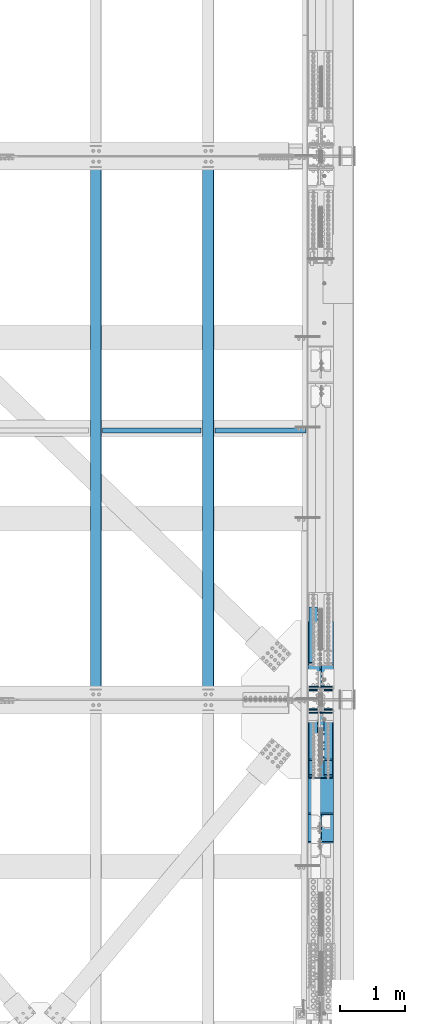
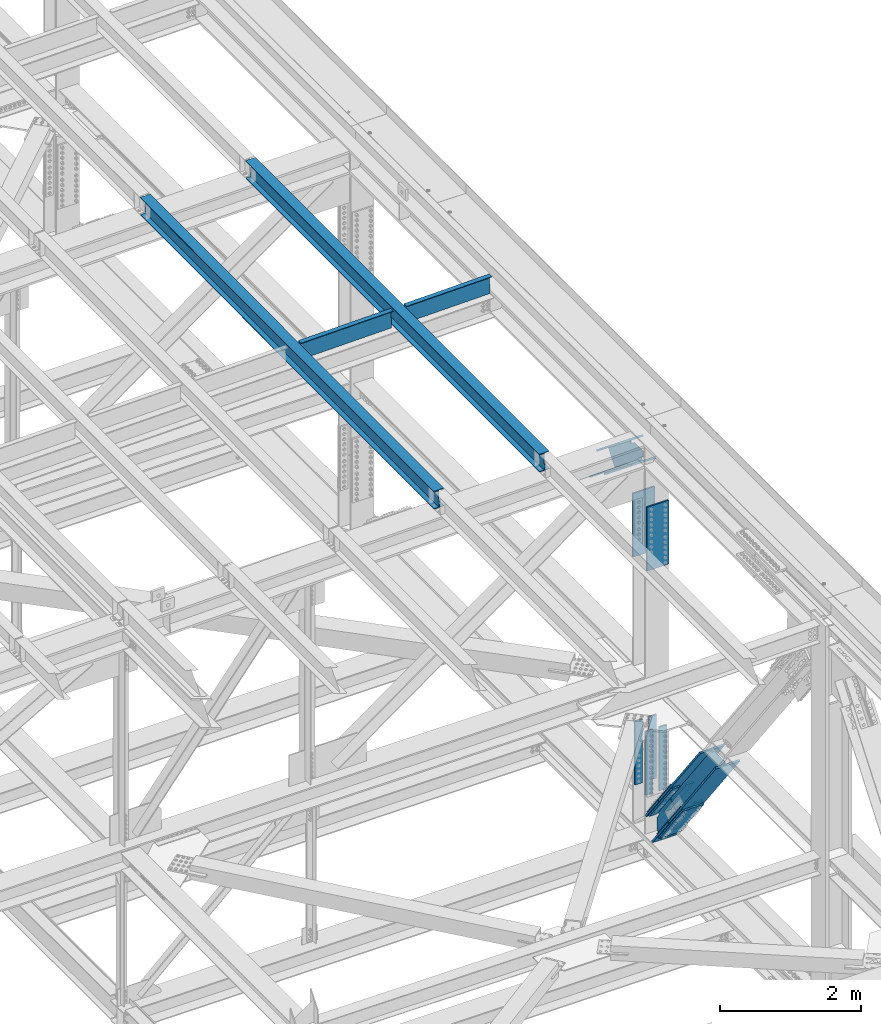
# One storey, part 1961 of 3843: 10 beams, 10 members, 7 elements without a shape of their own.
"""IFC2X3 building model written with IfcOpenShell, lengths in millimetres."""

import ifcopenshell
import ifcopenshell.guid

model = None  # the IFC model being written
_history = None  # IfcOwnerHistory: only IFC2X3 demands one
_inside = {}  # id of a spatial element -> (the spatial element, [elements in it])
_under = {}  # id of a project, library or spatial element -> (it, [spatial elements below it])
_declared = {}  # id of a project -> (the project, [libraries it declares])
_typed = {}  # id of a type object -> (the type object, [elements of that type])
_made_of = {}  # id of a material, layer set ... -> (it, [elements and type objects made of it])


def new_model(schema):
    """Start an empty IFC model of exactly this schema.

    Asked for "IFC4X3", IfcOpenShell would pick the latest addendum, in which some entities
    have other attributes; the version numbers below select the first issue.
    IFC2X3 requires an IfcOwnerHistory on every rooted entity: one is made here for all.
    """
    global model, _history
    if schema == "IFC4X3":
        model = ifcopenshell.file(schema_version=(4, 3, 0, 0))
    else:
        model = ifcopenshell.file(schema=schema)
    _inside.clear()
    _under.clear()
    _declared.clear()
    _typed.clear()
    _made_of.clear()
    _history = None
    if model.schema == "IFC2X3":
        org = make("IfcOrganization", Name="unknown")
        user = make(
            "IfcPersonAndOrganization",
            ThePerson=make("IfcPerson", FamilyName="unknown"),
            TheOrganization=org,
        )
        app = make(
            "IfcApplication",
            ApplicationDeveloper=org,
            Version="unknown",
            ApplicationFullName="unknown",
            ApplicationIdentifier="unknown",
        )
        _history = make(
            "IfcOwnerHistory",
            OwningUser=user,
            OwningApplication=app,
            ChangeAction="ADDED",
            CreationDate=0,
        )
    return model


def make(cls, **values):
    """One entity of the class cls with the attributes given. An attribute that is None is left unset."""
    return model.create_entity(
        cls, **{name: value for name, value in values.items() if value is not None}
    )


def rooted(cls, **values):
    """An entity with a GlobalId (a new one), such as an element, a storey or a relation."""
    return make(cls, GlobalId=ifcopenshell.guid.new(), OwnerHistory=_history, **values)


def si_unit(unit_type, name, prefix=None):
    """IfcSIUnit, for example si_unit("LENGTHUNIT", "METRE", prefix="MILLI")."""
    return make("IfcSIUnit", UnitType=unit_type, Prefix=prefix, Name=name)


def assignment(units):
    """IfcUnitAssignment: the units of a project."""
    return None if units is None else make("IfcUnitAssignment", Units=units)


def point(xyz):
    """IfcCartesianPoint."""
    return None if xyz is None else make("IfcCartesianPoint", Coordinates=xyz)


def direction(xyz):
    """IfcDirection."""
    return None if xyz is None else make("IfcDirection", DirectionRatios=xyz)


def frame(location, z_axis=None, x_axis=None):
    """IfcAxis2Placement3D, a coordinate frame: its origin and axes. An axis left out is left unset."""
    return make(
        "IfcAxis2Placement3D",
        Location=point(location),
        Axis=direction(z_axis),
        RefDirection=direction(x_axis),
    )


def origin_with_axes():
    """The frame at (0, 0, 0) with the z axis (0, 0, 1) and the x axis (1, 0, 0) written out."""
    return frame((0.0, 0.0, 0.0), z_axis=(0.0, 0.0, 1.0), x_axis=(1.0, 0.0, 0.0))


def place(relative_to, where):
    """IfcLocalPlacement: puts the frame where relative to a parent placement (None: the world)."""
    return make(
        "IfcLocalPlacement", PlacementRelTo=relative_to, RelativePlacement=where
    )


def context(
    kind, dimensions, precision=None, world=None, true_north=None, identifier=None
):
    """IfcGeometricRepresentationContext, for example the 3D "Model" context."""
    return make(
        "IfcGeometricRepresentationContext",
        ContextIdentifier=identifier,
        ContextType=kind,
        CoordinateSpaceDimension=dimensions,
        Precision=precision,
        WorldCoordinateSystem=world,
        TrueNorth=true_north,
    )


def subcontext(parent, identifier, kind, view, scale=None):
    """IfcGeometricRepresentationSubContext, for example "Body" below "Model"."""
    return make(
        "IfcGeometricRepresentationSubContext",
        ContextIdentifier=identifier,
        ContextType=kind,
        ParentContext=parent,
        TargetScale=scale,
        TargetView=view,
    )


def project(units=None, contexts=None):
    """IfcProject with its units and contexts."""
    return rooted(
        "IfcProject",
        Name="project",
        RepresentationContexts=contexts,
        UnitsInContext=assignment(units),
    )


def spatial(cls, under=None, at=None, **own):
    """A site, building, storey or space (cls), placed at a placement, below another one or the project."""
    s = rooted(cls, ObjectPlacement=at, **own)
    if under is not None:
        _under.setdefault(under.id(), (under, []))[1].append(s)
    return s


def faces_of(points, faces, orient=None, outer=None):
    """IfcFace entities. A face is a list of loops; a loop is a list of indices into points, from 0.

    orient and outer hold one flag for each loop. By default every Orientation is true, the
    first loop of a face is its IfcFaceOuterBound and the others are IfcFaceBound.
    """
    made = []
    for i, loops in enumerate(faces):
        bounds = []
        for j, loop in enumerate(loops):
            is_outer = j == 0 if outer is None else outer[i][j]
            bounds.append(
                make(
                    "IfcFaceOuterBound" if is_outer else "IfcFaceBound",
                    Bound=make("IfcPolyLoop", Polygon=[points[k] for k in loop]),
                    Orientation=True if orient is None else orient[i][j],
                )
            )
        made.append(make("IfcFace", Bounds=bounds))
    return made


def faceted_brep(points, faces, orient=None, outer=None, voids=None):
    """IfcFacetedBrep: a solid bounded by flat faces; with voids (closed shells), ...WithVoids."""
    shared = [point(p) for p in points]
    hull = make("IfcClosedShell", CfsFaces=faces_of(shared, faces, orient, outer))
    if voids is None:
        return make("IfcFacetedBrep", Outer=hull)
    return make(
        "IfcFacetedBrepWithVoids",
        Outer=hull,
        Voids=[
            make(cls, CfsFaces=faces_of(shared, fs, o, b)) for cls, fs, o, b in voids
        ],
    )


def shape(context_of_items, identifier, shape_type, items):
    """IfcShapeRepresentation: the items that make up one representation, for example the "Body"."""
    return make(
        "IfcShapeRepresentation",
        ContextOfItems=context_of_items,
        RepresentationIdentifier=identifier,
        RepresentationType=shape_type,
        Items=items,
    )


def material(Name=None, Category=None):
    """IfcMaterial."""
    return make("IfcMaterial", Name=Name, Category=Category)


def made_of(thing, what):
    """Note that an element or type object is made of a material, layer set ...; save() writes the relation."""
    if what is not None:
        _made_of.setdefault(what.id(), (what, []))[1].append(thing)
    return thing


def type_object(cls, material=None, **own):
    """A type object (cls), such as IfcWallType, which elements share."""
    return made_of(rooted(cls, **own), material)


def element(
    cls,
    number,
    at=None,
    inside=None,
    cuts=None,
    type_object=None,
    material=None,
    context=None,
    identifier="Body",
    shape_type=None,
    held_by="IfcProductDefinitionShape",
    body=None,
    shapes=None,
    **own,
):
    """One element of the class cls, such as IfcWall. Its Tag is "e" and its number.

    at: its placement. inside: the storey or other place that contains it. cuts: it is an
    opening in that element (IfcRelVoidsElement). A single representation is given by context,
    identifier, shape_type and body (its items); several are given by shapes. held_by: the class
    of the entity that holds the representations. save() writes the other relations.
    """
    e = rooted(cls, Tag="e%d" % number, ObjectPlacement=at, **own)
    if body is not None:
        shapes = [shape(context, identifier, shape_type, body)]
    if shapes is not None:
        e.Representation = make(held_by, Representations=shapes)
    if inside is not None:
        _inside.setdefault(inside.id(), (inside, []))[1].append(e)
    if cuts is not None:
        rooted(
            "IfcRelVoidsElement", RelatingBuildingElement=cuts, RelatedOpeningElement=e
        )
    if type_object is not None:
        _typed.setdefault(type_object.id(), (type_object, []))[1].append(e)
    return made_of(e, material)


def aggregate(whole, parts):
    """IfcRelAggregates: a whole, such as a stair, and the parts it consists of."""
    return rooted("IfcRelAggregates", RelatingObject=whole, RelatedObjects=parts)


def save(model, path):
    """Write the relations noted so far, then the file.

    IfcRelAggregates (storeys below a building ...), IfcRelContainedInSpatialStructure (elements
    in a storey), IfcRelDefinesByType, IfcRelAssociatesMaterial and IfcRelDeclares: one each for
    every whole, place, type object, material and project.
    """
    for whole, parts in _under.values():
        aggregate(whole, parts)
    for where, things in _inside.values():
        rooted(
            "IfcRelContainedInSpatialStructure",
            RelatedElements=things,
            RelatingStructure=where,
        )
    for kind, things in _typed.values():
        rooted("IfcRelDefinesByType", RelatedObjects=things, RelatingType=kind)
    for what, things in _made_of.values():
        rooted("IfcRelAssociatesMaterial", RelatedObjects=things, RelatingMaterial=what)
    for by, libraries in _declared.values():
        rooted("IfcRelDeclares", RelatingContext=by, RelatedDefinitions=libraries)
    model.write(path)


model = new_model("IFC2X3")

# Units and contexts
model_context = context("Model", 3, precision=1e-05, world=origin_with_axes())
body_context = subcontext(model_context, "Body", "Model", "MODEL_VIEW")
ifc_project = project(units=[si_unit("LENGTHUNIT", "METRE", prefix="MILLI"), si_unit("AREAUNIT", "SQUARE_METRE"), si_unit("VOLUMEUNIT", "CUBIC_METRE"), si_unit("MASSUNIT", "GRAM", prefix="KILO"), si_unit("TIMEUNIT", "SECOND"), si_unit("PLANEANGLEUNIT", "RADIAN"), si_unit("SOLIDANGLEUNIT", "STERADIAN"), si_unit("THERMODYNAMICTEMPERATUREUNIT", "DEGREE_CELSIUS"), si_unit("LUMINOUSINTENSITYUNIT", "LUMEN")], contexts=[model_context])

# Site, building, storey
site_placement = place(None, origin_with_axes())
site = spatial("IfcSite", under=ifc_project, at=site_placement, CompositionType="ELEMENT")
building_placement = place(site_placement, origin_with_axes())
building = spatial("IfcBuilding", under=site, at=building_placement, Name="Undefined", CompositionType="ELEMENT")
storey_placement = place(building_placement, origin_with_axes())
storey = spatial("IfcBuildingStorey", under=building, at=storey_placement, Name="Undefined", CompositionType="ELEMENT", Elevation=0.0)

# Assembly, beam
assembly_1_placement = place(storey_placement, origin_with_axes())
assembly_1 = element("IfcElementAssembly", 1, at=assembly_1_placement, inside=storey, Name="BEAM", AssemblyPlace="NOTDEFINED", PredefinedType="RIGID_FRAME")
ifc_material_1 = material(Name="STEEL/A992")
beam_type_1 = type_object("IfcBeamType", Name="W12X26", PredefinedType="NOTDEFINED")
beam_1_placement = place(assembly_1_placement, frame((83918.3092623582, 33844.8446131286, 46598.2318088328), z_axis=(-0.0211520977821637, -0.00421267500005342, 0.999767394011606), x_axis=(0.0, 0.999991122676491, 0.00421361699863727)))
beam_1 = element("IfcBeam", 2, at=beam_1_placement, type_object=beam_type_1, material=ifc_material_1, Name="BEAM", ObjectType="W12X26", context=body_context, shape_type="Brep", body=[
    faceted_brep([(12.6927553268761, 82.550000001429, -155.57499999951), (12.7328814056527, 82.5500000013562, -146.049999999515), (8344.00684082649, 82.550000000876, -146.049999976771), (8343.96671474772, 82.5500000009488, -155.574999976765), (12.7399559111145, 3.17500000091968, -146.049999999763), (8344.01391533195, 3.17500000045402, -146.049999977025), (13.9704889935456, 3.17499999908614, 146.04999999985), (8345.24444841438, 3.17499999860593, 146.050000022587), (13.9634144880838, 82.5499999994936, 146.050000000097), (8345.23737390892, 82.5499999990279, 146.050000022835), (14.0035405668605, 82.5499999994499, 155.575000000084), (8345.2774999877, 82.5499999989843, 155.575000022829), (14.0182555382198, -82.5500000014581, 155.574999999568), (8345.29221495904, -82.5500000019383, 155.575000022312), (13.9781294594432, -82.5500000013853, 146.049999999581), (8345.25208888028, -82.5500000018656, 146.050000022326), (13.9710549539814, -3.17500000094878, 146.049999999828), (8345.24501437482, -3.175000001429, 146.050000022573), (12.7405218715503, -3.17499999910069, -146.049999999792), (8344.01448129239, -3.17499999956635, -146.04999997704), (12.7475963770048, -82.5499999995227, -146.050000000039), (8344.02155579784, -82.5500000000029, -146.049999977287), (12.7074702982354, -82.549999999479, -155.575000000019), (8343.98142971907, -82.5499999999593, -155.574999977282)], [[[0, 1, 2, 3]], [[1, 4, 5, 2]], [[4, 6, 7, 5]], [[6, 8, 9, 7]], [[8, 10, 11, 9]], [[10, 12, 13, 11]], [[12, 14, 15, 13]], [[14, 16, 17, 15]], [[16, 18, 19, 17]], [[18, 20, 21, 19]], [[20, 22, 23, 21]], [[22, 0, 3, 23]], [[5, 7, 9, 11, 13, 15, 17, 19, 21, 23, 3, 2]], [[22, 20, 18, 16, 14, 12, 10, 8, 6, 4, 1, 0]]]),
])
aggregate(assembly_1, [beam_1])

assembly_2_placement = place(storey_placement, origin_with_axes())
assembly_2 = element("IfcElementAssembly", 3, at=assembly_2_placement, inside=storey, Name="BEAM", AssemblyPlace="NOTDEFINED", PredefinedType="RIGID_FRAME")
beam_2_placement = place(assembly_2_placement, frame((82191.1092623704, 33844.7408271393, 46560.6475785564), z_axis=(-0.0211520979626948, -0.00487978700220265, 0.999764360452297), x_axis=(0.0, 0.999988088439141, 0.00488087900214347)))
beam_2 = element("IfcBeam", 4, at=beam_2_placement, type_object=beam_type_1, material=ifc_material_1, Name="BEAM", ObjectType="W12X26", context=body_context, shape_type="Brep", body=[
    faceted_brep([(12.691628644483, 82.5500000006432, -155.57500000007), (12.7381091693387, 82.5500000006432, -146.050000000068), (8344.03734800273, 82.5500000007451, -146.050000004936), (8343.99086747787, 82.5500000007451, -155.57500000493), (12.7463040077855, 3.17500000019209, -146.049999999967), (8344.04554284117, 3.17500000029395, -146.050000004834), (14.1717067699792, 3.17499999982829, 146.049999999952), (8345.47094560337, 3.17499999993015, 146.049999995084), (14.1635119315397, 82.5500000002794, 146.049999999857), (8345.46275076493, 82.5500000003813, 146.04999999499), (14.2099924563954, 82.5500000002648, 155.574999999844), (8345.50923128978, 82.5500000003667, 155.574999994977), (14.2270377203604, -82.5500000006723, 155.575000000055), (8345.52627655374, -82.5500000005704, 155.574999995188), (14.1805571955047, -82.5500000006577, 146.050000000068), (8345.47979602889, -82.5500000005559, 146.049999995201), (14.1723623570579, -3.17500000020664, 146.049999999967), (8345.47160119045, -3.17500000010477, 146.049999995099), (12.7469595948569, -3.17499999985739, -146.049999999952), (8344.04619842824, -3.17499999975553, -146.05000000482), (12.7551544333037, -82.5500000003085, -146.049999999857), (8344.05439326669, -82.5500000002066, -146.050000004725), (12.7086739084407, -82.5500000002939, -155.574999999844), (8344.00791274184, -82.5500000001921, -155.575000004712)], [[[0, 1, 2, 3]], [[1, 4, 5, 2]], [[4, 6, 7, 5]], [[6, 8, 9, 7]], [[8, 10, 11, 9]], [[10, 12, 13, 11]], [[12, 14, 15, 13]], [[14, 16, 17, 15]], [[16, 18, 19, 17]], [[18, 20, 21, 19]], [[20, 22, 23, 21]], [[22, 0, 3, 23]], [[5, 7, 9, 11, 13, 15, 17, 19, 21, 23, 3, 2]], [[22, 20, 18, 16, 14, 12, 10, 8, 6, 4, 1, 0]]]),
])
aggregate(assembly_2, [beam_2])

assembly_3_placement = place(storey_placement, origin_with_axes())
assembly_3 = element("IfcElementAssembly", 5, at=assembly_3_placement, inside=storey, Name="BENT_PLATE", AssemblyPlace="NOTDEFINED", PredefinedType="RIGID_FRAME")
ifc_material_2 = material(Name="STEEL/A36")
beam_type_2 = type_object("IfcBeamType", PredefinedType="NOTDEFINED")
beam_3_placement = place(assembly_3_placement, frame((83057.2130669715, 38019.0374999949, 46415.2203465508), z_axis=(-0.999817430718778, 0.0, -0.0191077269946473), x_axis=(-0.0191077269946443, 0.0, 0.999817430718778)))
beam_3 = element("IfcBeam", 6, at=beam_3_placement, type_object=beam_type_2, material=ifc_material_2, Name="BENT_PLATE", context=body_context, shape_type="Brep", body=[
    faceted_brep([(2.38651409745216e-09, -4.76249999999709, -755.649999997448), (-2.37923813983798e-09, -4.76249999999709, 755.649999997433), (-2.37923813983798e-09, 4.76249999999709, 755.649999997433), (2.38651409745216e-09, 4.76249999999709, -755.649999997448), (336.54999997891, 4.76249999995343, 755.649999998495), (336.549999983821, 4.76249999995343, -755.649999996385), (327.024999983856, -4.76250000004075, -755.649999996414), (327.024999978938, -4.76250000004075, 755.649999998466), (336.549999978997, -71.4375000010259, 755.649999998495), (336.549999983719, -71.4375000011714, -755.649999996371), (327.024999979025, -71.4375000010259, 755.649999998481), (327.024999983762, -71.4375000011714, -755.6499999964)], [[[0, 1, 2, 3]], [[3, 2, 4, 5]], [[1, 0, 6, 7]], [[5, 4, 8, 9]], [[4, 2, 1, 7, 10, 8]], [[7, 6, 11, 10]], [[6, 0, 3, 5, 9, 11]], [[10, 11, 9, 8]]]),
])
aggregate(assembly_3, [beam_3])

assembly_4_placement = place(storey_placement, origin_with_axes())
assembly_4 = element("IfcElementAssembly", 7, at=assembly_4_placement, inside=storey, Name="BENT_PLATE", AssemblyPlace="NOTDEFINED", PredefinedType="RIGID_FRAME")
beam_4_placement = place(assembly_4_placement, frame((84727.7934840697, 38019.0374999953, 46446.9663687485), z_axis=(-0.999817430718778, 0.0, -0.0191077269946473), x_axis=(-0.0191077269946443, 0.0, 0.999817430718778)))
beam_4 = element("IfcBeam", 8, at=beam_4_placement, type_object=beam_type_2, material=ifc_material_2, Name="BENT_PLATE", context=body_context, shape_type="Brep", body=[
    faceted_brep([(2.20461515709758e-09, -4.76249999999709, -698.499999997657), (-2.19733919948339e-09, -4.76249999999709, 698.499999997628), (-2.19733919948339e-09, 4.76249999999709, 698.499999997628), (2.20461515709758e-09, 4.76249999999709, -698.499999997657), (336.549999979979, 4.76249999995343, 698.499999998676), (336.549999984527, 4.76249999995343, -698.499999996595), (327.024999984562, -4.76250000004075, -698.499999996624), (327.024999980014, -4.76250000004075, 698.499999998647), (336.54999998006, -71.4375000010041, 698.499999998676), (336.54999998444, -71.4375000011423, -698.499999996595), (327.024999980094, -71.4375000009968, 698.499999998661), (327.024999984467, -71.437500001135, -698.499999996609)], [[[0, 1, 2, 3]], [[3, 2, 4, 5]], [[1, 0, 6, 7]], [[5, 4, 8, 9]], [[4, 2, 1, 7, 10, 8]], [[7, 6, 11, 10]], [[6, 0, 3, 5, 9, 11]], [[10, 11, 9, 8]]]),
])
aggregate(assembly_4, [beam_4])

# Assembly, member
assembly_5_placement = place(storey_placement, origin_with_axes())
assembly_5 = element("IfcElementAssembly", 9, at=assembly_5_placement, inside=storey, Name="BEAM", AssemblyPlace="NOTDEFINED", PredefinedType="RIGID_FRAME")
ifc_material_3 = material(Name="STEEL/A572-50")
member_type_1 = type_object("IfcMemberType", PredefinedType="NOTDEFINED")
member_1_placement = place(assembly_5_placement, frame((85534.5, 35267.4768249211, 44935.1767414138), z_axis=(1.0, 0.0, 0.0), x_axis=(0.0, -0.778233356227861, 0.62797519318387)))
member_1 = element("IfcMember", 10, at=member_1_placement, type_object=member_type_1, material=ifc_material_3, Name="PLATE", context=body_context, shape_type="Brep", body=[
    faceted_brep([(-4.36557456851006e-11, 12.7000000000116, -63.5), (-4.36557456851006e-11, 12.7000000000116, 63.5), (1104.90000001677, 12.7000000017251, 63.5), (1104.90000001677, 12.7000000017251, -63.5), (1.45519152283669e-11, -12.700000000008, 63.5), (1104.90000001682, -12.6999999982909, 63.5), (1.45519152283669e-11, -12.700000000008, -63.5), (1104.90000001682, -12.6999999982909, -63.5)], [[[0, 1, 2, 3]], [[1, 4, 5, 2]], [[4, 6, 7, 5]], [[6, 0, 3, 7]], [[5, 7, 3, 2]], [[6, 4, 1, 0]]]),
])

# Assembly, members, beams
assembly_6_placement = place(storey_placement, origin_with_axes())
assembly_6 = element("IfcElementAssembly", 11, at=assembly_6_placement, inside=storey, Name="BEAM", AssemblyPlace="NOTDEFINED", PredefinedType="RIGID_FRAME")
member_2_placement = place(assembly_6_placement, frame((85763.1, 32685.9466937184, 40781.2415149901), z_axis=(-1.0, 0.0, 0.0), x_axis=(0.0, 0.605220639686578, -0.79605777258775)))
member_2 = element("IfcMember", 12, at=member_2_placement, type_object=member_type_1, material=ifc_material_3, Name="PLATE", context=body_context, shape_type="Brep", body=[
    faceted_brep([(-4.36557456851006e-11, 12.7000000000116, -63.5), (-4.36557456851006e-11, 12.7000000000116, 63.5), (1104.90000001677, 12.7000000017251, 63.5), (1104.90000001677, 12.7000000017251, -63.5), (1.45519152283669e-11, -12.700000000008, 63.5), (1104.90000001682, -12.6999999982909, 63.5), (1.45519152283669e-11, -12.700000000008, -63.5), (1104.90000001682, -12.6999999982909, -63.5)], [[[0, 1, 2, 3]], [[1, 4, 5, 2]], [[4, 6, 7, 5]], [[6, 0, 3, 7]], [[5, 7, 3, 2]], [[6, 4, 1, 0]]]),
])
member_3_placement = place(assembly_6_placement, frame((85763.1, 32921.0026948762, 40959.9479836669), z_axis=(-1.0, 0.0, 0.0), x_axis=(0.0, 0.605220639686578, -0.79605777258775)))
member_3 = element("IfcMember", 13, at=member_3_placement, type_object=member_type_1, material=ifc_material_3, Name="PLATE", context=body_context, shape_type="Brep", body=[
    faceted_brep([(-4.36557456851006e-11, 12.7000000000116, -63.5), (-4.36557456851006e-11, 12.7000000000116, 63.5), (1104.90000001677, 12.7000000017251, 63.5), (1104.90000001677, 12.7000000017251, -63.5), (1.45519152283669e-11, -12.700000000008, 63.5), (1104.90000001682, -12.6999999982909, 63.5), (1.45519152283669e-11, -12.700000000008, -63.5), (1104.90000001682, -12.6999999982909, -63.5)], [[[0, 1, 2, 3]], [[1, 4, 5, 2]], [[4, 6, 7, 5]], [[6, 0, 3, 7]], [[5, 7, 3, 2]], [[6, 4, 1, 0]]]),
])
member_4_placement = place(assembly_6_placement, frame((85534.5, 32685.9580656035, 40781.2501607145), z_axis=(-1.0, 0.0, 0.0), x_axis=(0.0, 0.605220639686578, -0.79605777258775)))
member_4 = element("IfcMember", 14, at=member_4_placement, type_object=member_type_1, material=ifc_material_3, Name="PLATE", context=body_context, shape_type="Brep", body=[
    faceted_brep([(-4.36557456851006e-11, 12.7000000000116, -63.5), (-4.36557456851006e-11, 12.7000000000116, 63.5), (1104.90000001677, 12.7000000017251, 63.5), (1104.90000001677, 12.7000000017251, -63.5), (1.45519152283669e-11, -12.700000000008, 63.5), (1104.90000001682, -12.6999999982909, 63.5), (1.45519152283669e-11, -12.700000000008, -63.5), (1104.90000001682, -12.6999999982909, -63.5)], [[[0, 1, 2, 3]], [[1, 4, 5, 2]], [[4, 6, 7, 5]], [[6, 0, 3, 7]], [[5, 7, 3, 2]], [[6, 4, 1, 0]]]),
])
member_5_placement = place(assembly_6_placement, frame((85534.5, 32921.0026948767, 40959.9479836673), z_axis=(-1.0, 0.0, 0.0), x_axis=(0.0, 0.605220639686578, -0.79605777258775)))
member_5 = element("IfcMember", 15, at=member_5_placement, type_object=member_type_1, material=ifc_material_3, Name="PLATE", context=body_context, shape_type="Brep", body=[
    faceted_brep([(-4.36557456851006e-11, 12.7000000000116, -63.5), (-4.36557456851006e-11, 12.7000000000116, 63.5), (1104.90000001677, 12.7000000017251, 63.5), (1104.90000001677, 12.7000000017251, -63.5), (1.45519152283669e-11, -12.700000000008, 63.5), (1104.90000001682, -12.6999999982909, 63.5), (1.45519152283669e-11, -12.700000000008, -63.5), (1104.90000001682, -12.6999999982909, -63.5)], [[[0, 1, 2, 3]], [[1, 4, 5, 2]], [[4, 6, 7, 5]], [[6, 0, 3, 7]], [[5, 7, 3, 2]], [[6, 4, 1, 0]]]),
])
member_type_2 = type_object("IfcMemberType", PredefinedType="NOTDEFINED")
member_6_placement = place(assembly_6_placement, frame((85648.8, 33310.4238020969, 39868.0495622512), z_axis=(-1.0, 0.0, 0.0), x_axis=(0.0, -0.605220451019698, 0.796057916025909)))
member_6 = element("IfcMember", 16, at=member_6_placement, type_object=member_type_2, material=ifc_material_3, Name="PLATE", context=body_context, shape_type="Brep", body=[
    faceted_brep([(-1.45519152283669e-11, 12.7000000000025, -177.800000000003), (-1.45519152283669e-11, 12.7000000000025, 177.800000000003), (1104.90000001682, 12.7000000017051, 177.800000000003), (1104.90000001682, 12.7000000017051, -177.800000000003), (4.36557456851006e-11, -12.7000000000171, 177.800000000003), (1104.90000001686, -12.6999999983072, 177.800000000003), (4.36557456851006e-11, -12.7000000000171, -177.800000000003), (1104.90000001686, -12.6999999983072, -177.800000000003)], [[[0, 1, 2, 3]], [[1, 4, 5, 2]], [[4, 6, 7, 5]], [[6, 0, 3, 7]], [[5, 7, 3, 2]], [[6, 4, 1, 0]]]),
])
member_7_placement = place(assembly_6_placement, frame((85648.8, 33633.9417391749, 40114.0111535488), z_axis=(-1.0, 0.0, 0.0), x_axis=(0.0, -0.605220451019698, 0.796057916025909)))
member_7 = element("IfcMember", 17, at=member_7_placement, type_object=member_type_2, material=ifc_material_3, Name="PLATE", context=body_context, shape_type="Brep", body=[
    faceted_brep([(-1.45519152283669e-11, 12.7000000000025, -177.800000000003), (-1.45519152283669e-11, 12.7000000000025, 177.800000000003), (1104.90000001682, 12.7000000017051, 177.800000000003), (1104.90000001682, 12.7000000017051, -177.800000000003), (4.36557456851006e-11, -12.7000000000171, 177.800000000003), (1104.90000001686, -12.6999999983072, 177.800000000003), (4.36557456851006e-11, -12.7000000000171, -177.800000000003), (1104.90000001686, -12.6999999983072, -177.800000000003)], [[[0, 1, 2, 3]], [[1, 4, 5, 2]], [[4, 6, 7, 5]], [[6, 0, 3, 7]], [[5, 7, 3, 2]], [[6, 4, 1, 0]]]),
])
beam_type_3 = type_object("IfcBeamType", PredefinedType="NOTDEFINED")
beam_5_placement = place(assembly_6_placement, frame((85763.1, 33697.8624999997, 41479.6132622932), z_axis=(-1.0, 0.0, 0.0), x_axis=(0.0, 0.0, -1.0)))
beam_5 = element("IfcBeam", 18, at=beam_5_placement, type_object=beam_type_3, material=ifc_material_3, Name="PLATE", context=body_context, shape_type="Brep", body=[
    faceted_brep([(-4.36557456851006e-11, 12.7000000000116, -63.5), (-4.36557456851006e-11, 12.7000000000116, 63.5), (1104.90000001677, 12.7000000017251, 63.5), (1104.90000001677, 12.7000000017251, -63.5), (1.45519152283669e-11, -12.700000000008, 63.5), (1104.90000001682, -12.6999999982909, 63.5), (1.45519152283669e-11, -12.700000000008, -63.5), (1104.90000001682, -12.6999999982909, -63.5)], [[[0, 1, 2, 3]], [[1, 4, 5, 2]], [[4, 6, 7, 5]], [[6, 0, 3, 7]], [[5, 7, 3, 2]], [[6, 4, 1, 0]]]),
])
beam_6_placement = place(assembly_6_placement, frame((85763.1, 33993.1374999997, 41479.6132622932), z_axis=(-1.0, 0.0, 0.0), x_axis=(0.0, 0.0, -1.0)))
beam_6 = element("IfcBeam", 19, at=beam_6_placement, type_object=beam_type_3, material=ifc_material_3, Name="PLATE", context=body_context, shape_type="Brep", body=[
    faceted_brep([(-4.36557456851006e-11, 12.7000000000116, -63.5), (-4.36557456851006e-11, 12.7000000000116, 63.5), (1104.90000001677, 12.7000000017251, 63.5), (1104.90000001677, 12.7000000017251, -63.5), (1.45519152283669e-11, -12.700000000008, 63.5), (1104.90000001682, -12.6999999982909, 63.5), (1.45519152283669e-11, -12.700000000008, -63.5), (1104.90000001682, -12.6999999982909, -63.5)], [[[0, 1, 2, 3]], [[1, 4, 5, 2]], [[4, 6, 7, 5]], [[6, 0, 3, 7]], [[5, 7, 3, 2]], [[6, 4, 1, 0]]]),
])
beam_7_placement = place(assembly_6_placement, frame((85534.5, 33697.8624999997, 41479.6132622932), z_axis=(-1.0, 0.0, 0.0), x_axis=(0.0, 0.0, -1.0)))
beam_7 = element("IfcBeam", 20, at=beam_7_placement, type_object=beam_type_3, material=ifc_material_3, Name="PLATE", context=body_context, shape_type="Brep", body=[
    faceted_brep([(-4.36557456851006e-11, 12.7000000000116, -63.5), (-4.36557456851006e-11, 12.7000000000116, 63.5), (1104.90000001677, 12.7000000017251, 63.5), (1104.90000001677, 12.7000000017251, -63.5), (1.45519152283669e-11, -12.700000000008, 63.5), (1104.90000001682, -12.6999999982909, 63.5), (1.45519152283669e-11, -12.700000000008, -63.5), (1104.90000001682, -12.6999999982909, -63.5)], [[[0, 1, 2, 3]], [[1, 4, 5, 2]], [[4, 6, 7, 5]], [[6, 0, 3, 7]], [[5, 7, 3, 2]], [[6, 4, 1, 0]]]),
])
beam_8_placement = place(assembly_6_placement, frame((85534.5, 33993.1374999997, 41479.6132622932), z_axis=(-1.0, 0.0, 0.0), x_axis=(0.0, 0.0, -1.0)))
beam_8 = element("IfcBeam", 21, at=beam_8_placement, type_object=beam_type_3, material=ifc_material_3, Name="PLATE", context=body_context, shape_type="Brep", body=[
    faceted_brep([(-4.36557456851006e-11, 12.7000000000116, -63.5), (-4.36557456851006e-11, 12.7000000000116, 63.5), (1104.90000001677, 12.7000000017251, 63.5), (1104.90000001677, 12.7000000017251, -63.5), (1.45519152283669e-11, -12.700000000008, 63.5), (1104.90000001682, -12.6999999982909, 63.5), (1.45519152283669e-11, -12.700000000008, -63.5), (1104.90000001682, -12.6999999982909, -63.5)], [[[0, 1, 2, 3]], [[1, 4, 5, 2]], [[4, 6, 7, 5]], [[6, 0, 3, 7]], [[5, 7, 3, 2]], [[6, 4, 1, 0]]]),
])

# Beam
beam_type_4 = type_object("IfcBeamType", PredefinedType="NOTDEFINED")
beam_9_placement = place(assembly_5_placement, frame((85648.8, 33647.0624999834, 45397.5935411554), z_axis=(1.0, 0.0, 0.0), x_axis=(0.0, 0.0, -1.0)))
beam_9 = element("IfcBeam", 22, at=beam_9_placement, type_object=beam_type_4, material=ifc_material_3, Name="PLATE", context=body_context, shape_type="Brep", body=[
    faceted_brep([(-1.45519152283669e-11, 12.7000000000025, -177.800000000003), (-1.45519152283669e-11, 12.7000000000025, 177.800000000003), (1104.90000001682, 12.7000000017051, 177.800000000003), (1104.90000001682, 12.7000000017051, -177.800000000003), (4.36557456851006e-11, -12.7000000000171, 177.800000000003), (1104.90000001686, -12.6999999983072, 177.800000000003), (4.36557456851006e-11, -12.7000000000171, -177.800000000003), (1104.90000001686, -12.6999999983072, -177.800000000003)], [[[0, 1, 2, 3]], [[1, 4, 5, 2]], [[4, 6, 7, 5]], [[6, 0, 3, 7]], [[5, 7, 3, 2]], [[6, 4, 1, 0]]]),
])

beam_10_placement = place(assembly_5_placement, frame((85648.8, 34043.9375000082, 45397.5935411554), z_axis=(1.0, 0.0, 0.0), x_axis=(0.0, 0.0, -1.0)))
beam_10 = element("IfcBeam", 23, at=beam_10_placement, type_object=beam_type_4, material=ifc_material_3, Name="PLATE", context=body_context, shape_type="Brep", body=[
    faceted_brep([(-1.45519152283669e-11, 12.7000000000025, -177.800000000003), (-1.45519152283669e-11, 12.7000000000025, 177.800000000003), (1104.90000001682, 12.7000000017051, 177.800000000003), (1104.90000001682, 12.7000000017051, -177.800000000003), (4.36557456851006e-11, -12.7000000000171, 177.800000000003), (1104.90000001686, -12.6999999983072, 177.800000000003), (4.36557456851006e-11, -12.7000000000171, -177.800000000003), (1104.90000001686, -12.6999999983072, -177.800000000003)], [[[0, 1, 2, 3]], [[1, 4, 5, 2]], [[4, 6, 7, 5]], [[6, 0, 3, 7]], [[5, 7, 3, 2]], [[6, 4, 1, 0]]]),
])

# Member
member_type_3 = type_object("IfcMemberType", Name="W14X159", PredefinedType="NOTDEFINED")
member_8_placement = place(assembly_5_placement, frame((85648.8, 34930.2544945508, 45396.9980637705), z_axis=(0.0, 0.627975193183871, 0.77823335622786), x_axis=(0.0, -0.778233356227861, 0.62797519318387)))
member_8 = element("IfcMember", 24, at=member_8_placement, type_object=member_type_3, material=ifc_material_1, Name="BEAM", ObjectType="W14X159", context=body_context, shape_type="Brep", body=[
    faceted_brep([(965.274078010247, -9.52499999999418, -122.237500109914), (965.274078010247, 9.52499999999418, -122.237500109914), (1028.00769625687, 9.52499999999418, -122.237500145144), (1052.48621533554, -9.52499999999418, -122.237500158881), (960.24511979556, -9.52499999999418, -123.673297229965), (960.24511979556, 9.52499999999418, -123.673297229965), (956.732290508379, -9.52499999999418, -127.547824877816), (956.732290508379, 9.52499999999418, -127.547824877816), (955.794636948828, -9.52499999999418, -132.692991531789), (955.794636948828, 9.52499999999418, -132.692991531789), (957.71484265224, -9.52499999999418, -137.557633774704), (957.71484265224, 9.52499999999418, -137.557633774704), (975.178563895068, -9.52499999999418, -160.337500001056), (975.178563895068, 9.52499999999418, -160.337500001056), (975.178563895068, 198.4375, -160.337500001056), (6.34999999470892, 198.4375, -160.337499999619), (6.34999999470892, 9.52499999999418, -160.337499999619), (997.403563903121, 9.52499999999418, -160.337500001086), (997.403563903121, 198.4375, -160.337500001086), (785.514418211097, -9.52499999999418, 137.564905434003), (785.514418211097, 9.52499999999418, 137.564905434003), (803.007386431233, 9.52499999999418, 160.337499998335), (803.007386431233, -9.52499999999418, 160.337499998335), (783.589305972052, -9.52499999999418, 132.699832892089), (783.589305972052, 9.52499999999418, 132.699832892089), (784.524258379923, -9.52499999999418, 127.551935071999), (784.524258379923, 9.52499999999418, 127.551935071999), (788.037168665338, -9.52499999999418, 123.674506891133), (788.037168665338, 9.52499999999418, 123.674506891133), (793.068072959094, -9.52499999999418, 122.237499598799), (793.068072959094, 9.52499999999418, 122.237499598799), (909.127267789449, -9.52499999999418, 122.237499778785), (878.943754389883, 9.52499999999418, 122.237499688723), (1114.75195081057, -9.52500000008149, -45.0731903502165), (1088.01229667775, 9.52499999933934, -47.8753563192076), (6.34999999323918, 9.52499999999418, 160.337499999503), (6.34999999323918, -9.52499999999418, 160.337499999503), (6.34999999470892, -9.52499999999418, -160.337499999619), (6.34999999483989, -198.4375, -190.499999999538), (6.34999999483989, 198.4375, -190.499999999538), (996.463958310109, 198.4375, -190.500000001011), (996.463958310109, -198.4375, -190.500000001011), (975.178563895068, -198.4375, -160.337500001056), (6.34999999470892, -198.4375, -160.337499999619), (997.403563903121, -198.4375, -160.337500001086), (997.403563903121, -9.52499999999418, -160.337500001086), (6.34999999323918, -198.4375, 160.337499999503), (6.34999999309366, -198.4375, 190.499999999422), (6.34999999309366, 198.4375, 190.499999999422), (6.34999999323918, 198.4375, 160.337499999503), (803.007386431233, 198.4375, 160.337499998335), (825.232386445434, 198.4375, 160.337499998292), (825.232386445434, 9.52499999999418, 160.337499998292), (825.232386445434, -9.52499999999418, 160.337499998292), (803.007386431233, -198.4375, 160.337499998335), (825.232386445434, -198.4375, 160.337499998292), (825.232386434971, -198.4375, 190.499999634252), (825.232386434971, 198.4375, 190.499999998217)], [[[0, 1, 2, 3]], [[4, 5, 1, 0]], [[6, 7, 5, 4]], [[8, 9, 7, 6]], [[10, 11, 9, 8]], [[12, 13, 11, 10]], [[14, 15, 16, 13, 17, 18]], [[19, 20, 21, 22]], [[23, 24, 20, 19]], [[25, 26, 24, 23]], [[27, 28, 26, 25]], [[29, 30, 28, 27]], [[30, 29, 31, 32]], [[32, 31, 33, 34]], [[1, 5, 7, 9, 11, 13, 16, 35, 21, 20, 24, 26, 28, 30, 32, 34, 2]], [[33, 3, 2, 34]], [[31, 29, 27, 25, 23, 19, 22, 36, 37, 12, 10, 8, 6, 4, 0, 3, 33]], [[38, 39, 40, 41]], [[42, 43, 38, 41, 44]], [[12, 37, 43, 42, 44, 45]], [[13, 12, 45, 17]], [[44, 41, 40, 18, 17, 45]], [[39, 15, 14, 18, 40]], [[38, 43, 37, 36, 46, 47, 48, 49, 35, 16, 15, 39]], [[21, 35, 49, 50, 51, 52]], [[22, 21, 52, 53]], [[54, 46, 36, 22, 53, 55]], [[47, 46, 54, 55, 56]], [[48, 47, 56, 57]], [[50, 49, 48, 57, 51]], [[56, 55, 53, 52, 51, 57]]]),
])

aggregate(assembly_5, [member_1, beam_9, beam_10, member_8])

# Assembly, member
assembly_7_placement = place(storey_placement, origin_with_axes())
assembly_7 = element("IfcElementAssembly", 25, at=assembly_7_placement, inside=storey, Name="V. BRACE", AssemblyPlace="NOTDEFINED", PredefinedType="RIGID_FRAME")
member_9_placement = place(assembly_7_placement, frame((85648.8, 33137.8287324714, 40430.8125536112), z_axis=(0.0, 0.79605834489475, 0.605219886919978), x_axis=(0.0, -0.605220451019698, 0.796057916025909)))
member_9 = element("IfcMember", 26, at=member_9_placement, type_object=member_type_3, material=ifc_material_1, Name="V. BRACE", ObjectType="W14X159", context=body_context, shape_type="Brep", body=[
    faceted_brep([(2216.51825613153, -198.4375, -160.337457767571), (2216.51824059142, -198.4375, -190.499999996973), (2216.51824059142, 198.4375, -190.499999996973), (2216.51825613152, 198.4375, -160.33749999688), (2216.51825613152, 9.52499999999418, -160.33749999688), (2216.51825613153, -9.52499999999418, -160.337462772797), (1921.91964980419, 9.52499999999418, 160.337500003676), (6.35008261191251, 9.52499999999418, 160.337500000533), (6.35008261191251, 198.4375, 160.337500000533), (1921.91964980419, 198.4375, 160.337500003676), (1953.79489466684, 198.4375, 160.337500003727), (1953.79489466684, 9.52499999999418, 160.337500003727), (2165.71825613045, -9.52499999999418, -160.337499996967), (2165.71825613045, 9.52499999999418, -160.337499996967), (2148.37251011346, 9.52500024452456, -137.522219113569), (2148.37251011346, -9.52499999119027, -137.522219113569), (2146.4732654656, 9.52500024493202, -132.664693297367), (2146.4732654656, -9.52499999117572, -132.664693297367), (2147.41696306852, 9.52500024603796, -127.535158998639), (2147.41696306852, -9.52499999113206, -127.535158998639), (2150.92064964587, 9.52500024752226, -123.671628533484), (2150.92064964587, -9.52499999107386, -123.671628533484), (2155.93379842585, 9.52500024891924, -122.232522353501), (2155.93379842585, -9.5249999910302, -122.232522353501), (2187.78555013821, -9.52499998183339, -122.161742720797), (2163.97843707804, 9.52500053706171, -122.214645893386), (1979.75148310068, 9.5250005415146, 122.439402121905), (2003.65148927985, -9.5249999773805, 122.368942903136), (1927.63472877281, -9.52499999053543, 123.319769815862), (1924.54857086602, -9.52499999054999, 125.398145256433), (1922.49411501812, -9.52499999054999, 128.500277791754), (1921.78485501938, -9.52499999053543, 132.152806416132), (1921.91964980419, -9.52499999999418, 160.337500003676), (6.35008261191251, -9.52499999999418, 160.337500000533), (6.34991739613542, -9.52499999999418, -160.337500000503), (1931.28166533538, -9.52499999050633, 122.582295201842), (1921.91964980419, -198.4375, 160.337500003676), (6.35008261191251, -198.4375, 160.337500000533), (1953.79489466684, -9.52499999999418, 160.337500003727), (1953.79489466684, -198.4375, 160.337500003727), (6.35009815200829, -198.4375, 190.500000000626), (1953.79491027304, -198.4375, 190.500177596761), (6.35009815200829, 198.4375, 190.500000000626), (1953.79491027303, 198.4375, 190.50000000382), (1921.78485501938, 9.52500025440531, 132.152806416132), (1922.49411501812, 9.52500025402696, 128.500277791754), (1924.54857086602, 9.52500025404152, 125.398145256433), (1927.63472877281, 9.52500025443442, 123.319769815862), (1931.28166533538, 9.52500025511836, 122.582295201842), (6.34991739613542, 9.52499999999418, -160.337500000503), (6.34990185603965, -198.4375, -190.500000000604), (6.34991739613542, -198.4375, -160.337500000503), (6.34991739613542, 198.4375, -160.337500000503), (6.34990185603965, 198.4375, -190.500000000604), (2165.71825613045, -198.4375, -160.337499996967), (2165.71825613045, 198.4375, -160.337499996967)], [[[0, 1, 2, 3, 4, 5]], [[6, 7, 8, 9, 10, 11]], [[12, 13, 14, 15]], [[15, 14, 16, 17]], [[17, 16, 18, 19]], [[19, 18, 20, 21]], [[21, 20, 22, 23]], [[24, 23, 22, 25]], [[24, 25, 26, 27]], [[28, 29, 30, 31, 32, 33, 34, 12, 15, 17, 19, 21, 23, 24, 27, 35]], [[36, 37, 33, 32, 38, 39]], [[40, 37, 36, 39, 41]], [[42, 40, 41, 43]], [[9, 8, 42, 43, 10]], [[41, 39, 38, 11, 10, 43]], [[32, 6, 11, 38]], [[31, 44, 6, 32]], [[30, 45, 44, 31]], [[29, 46, 45, 30]], [[28, 47, 46, 29]], [[35, 48, 47, 28]], [[27, 26, 48, 35]], [[25, 22, 20, 18, 16, 14, 13, 49, 7, 6, 44, 45, 46, 47, 48, 26]], [[50, 51, 34, 33, 37, 40, 42, 8, 7, 49, 52, 53]], [[12, 34, 51, 54, 0, 5]], [[13, 12, 5, 4]], [[55, 52, 49, 13, 4, 3]], [[53, 52, 55, 3, 2]], [[50, 53, 2, 1]], [[54, 51, 50, 1, 0]]]),
])
aggregate(assembly_7, [member_9])

# Member
member_10_placement = place(assembly_6_placement, frame((85648.8, 33845.5, 39499.9991392354), z_axis=(0.0, 0.796057772587748, 0.60522063968658), x_axis=(0.0, -0.605220451019698, 0.796057916025909)))
member_10 = element("IfcMember", 27, at=member_10_placement, type_object=member_type_3, material=ifc_material_1, Name="BEAM", ObjectType="W14X159", context=body_context, shape_type="Brep", body=[
    faceted_brep([(504.353188521896, -9.52499932929641, 122.208345885272), (472.858035633746, 9.52499999999418, 122.19388454836), (281.78000935915, 9.52499999999418, -23.0774001134414), (308.410438455234, -9.52498214221851, -26.7614540145587), (439.737532939182, 9.52499999999418, -122.233564917311), (439.737532939182, -9.52499999999418, -122.233564917311), (380.367847592686, -9.52488606578845, -122.242867962617), (356.51662614003, 9.52499999999418, -122.24658824112), (444.768661451502, 9.52499999999418, -123.669786997569), (444.768661451502, -9.52499999999418, -123.669786997569), (448.282176860806, 9.52499999999418, -127.546666856419), (448.282176860806, -9.52499999999418, -127.546666856419), (449.21793271155, 9.52499999999418, -132.694418691834), (449.21793271155, -9.52499999999418, -132.694418691834), (447.293579808456, 9.52499999999418, -137.559791634958), (447.293579808456, -9.52499999999418, -137.559791634958), (429.804150453696, 9.52499999999418, -160.337499999718), (429.804150453696, -9.52499999999418, -160.337499999718), (1162.92851057496, 9.52499999999418, -160.337499998772), (1162.92851057496, 198.4375, -160.337499998772), (429.804150453696, 198.4375, -160.337499999718), (407.579150754653, 198.4375, -160.337499999747), (407.579150754653, 9.52499999999418, -160.337499999747), (407.579150754653, -9.52499999999418, -160.337499999747), (429.804150453696, -198.4375, -160.337499999718), (1162.92851057496, -198.4375, -160.337499998772), (1162.92851057496, -9.52499999999418, -160.337499998772), (407.579166307971, -198.4375, -160.338584558434), (1162.92851057496, -198.4375, -190.499999998807), (407.583855470279, -198.4375, -190.499999999811), (1162.92851057496, 198.4375, -190.499999998807), (407.583855470279, 198.4375, -190.499999999811), (1162.92851057496, 9.52499999999418, 160.337500001799), (1162.92851057496, 198.4375, 160.337500001799), (1162.92851057496, 198.4375, 190.500000001848), (1162.92851057496, -198.4375, 190.500000001848), (1162.92851057496, -198.4375, 160.337500001799), (1162.92851057496, -9.52499999999418, 160.337500001799), (583.995674180173, 198.4375, 160.337500001049), (583.995674180173, 9.52499999999418, 160.337500001049), (561.770725847557, 9.52499999999418, 160.337500001013), (561.770725847557, 198.4375, 160.337500001013), (562.706604905092, 198.4375, 190.500000001062), (562.706604905092, -198.4375, 190.500000001062), (583.995674180173, -198.4375, 160.337500001049), (561.770725847557, -198.4375, 160.337500001013), (583.995674180173, -9.52499999999418, 160.337500001049), (561.770725847557, -9.52499999999418, 160.337500001013), (601.467419965169, 9.52499999999418, 137.57078084621), (601.467419965169, -9.52499999999418, 137.57078084621), (603.388314252499, 9.52499999999418, 132.707156616765), (603.388314252499, -9.52499999999418, 132.707156616765), (602.452172786538, 9.52499999999418, 127.562420018636), (602.452172786538, -9.52499999999418, 127.562420018636), (598.941148340195, 9.52499999999418, 123.687193206475), (598.941148340195, -9.52499999999418, 123.687193206475), (593.913462687933, 9.52499999999418, 122.249468444767), (593.913462687933, -9.52499999999418, 122.249468444767)], [[[0, 1, 2, 3]], [[4, 5, 6, 7]], [[5, 4, 8, 9]], [[9, 8, 10, 11]], [[11, 10, 12, 13]], [[13, 12, 14, 15]], [[15, 14, 16, 17]], [[16, 18, 19, 20, 21, 22]], [[17, 16, 22, 23]], [[24, 25, 26, 17, 23, 27]], [[28, 25, 24, 27, 29]], [[30, 28, 29, 31]], [[27, 23, 22, 21, 31, 29]], [[20, 19, 30, 31, 21]], [[18, 32, 33, 34, 35, 36, 37, 26, 25, 28, 30, 19]], [[38, 33, 32, 39, 40, 41]], [[34, 33, 38, 41, 42]], [[35, 34, 42, 43]], [[44, 36, 35, 43, 45]], [[46, 37, 36, 44, 45, 47]], [[43, 42, 41, 40, 47, 45]], [[39, 46, 47, 40]], [[46, 39, 48, 49]], [[49, 48, 50, 51]], [[51, 50, 52, 53]], [[53, 52, 54, 55]], [[55, 54, 56, 57]], [[6, 5, 9, 11, 13, 15, 17, 26, 37, 46, 49, 51, 53, 55, 57, 0, 3]], [[7, 6, 3, 2]], [[56, 54, 52, 50, 48, 39, 32, 18, 16, 14, 12, 10, 8, 4, 7, 2, 1]], [[57, 56, 1, 0]]]),
])

aggregate(assembly_6, [member_2, member_3, member_4, member_5, member_6, member_7, beam_5, beam_6, beam_7, beam_8, member_10])

save(model, "model.ifc")
